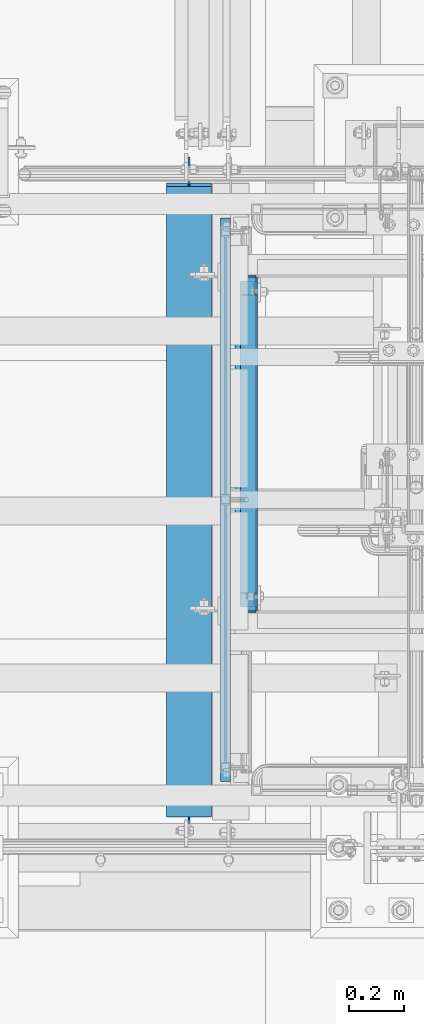
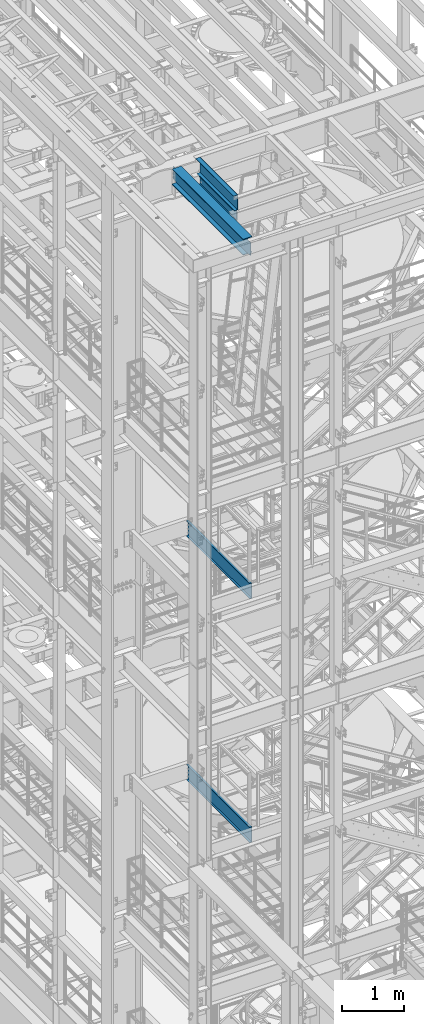
# One storey, part 955 of 1876: 6 beams, 5 elements without a shape of their own.
"""IFC2X3 building model written with IfcOpenShell, lengths in millimetres."""

from ifc_helpers import new_model, si_unit, frame, origin_with_axes, place, context, subcontext, project, spatial, faceted_brep, material, type_object, element, aggregate, save


model = new_model("IFC2X3")

# Units and contexts
model_context = context("Model", 3, precision=1e-05, world=origin_with_axes())
body_context = subcontext(model_context, "Body", "Model", "MODEL_VIEW")
ifc_project = project(units=[si_unit("LENGTHUNIT", "METRE", prefix="MILLI"), si_unit("AREAUNIT", "SQUARE_METRE"), si_unit("VOLUMEUNIT", "CUBIC_METRE"), si_unit("MASSUNIT", "GRAM", prefix="KILO"), si_unit("TIMEUNIT", "SECOND"), si_unit("PLANEANGLEUNIT", "RADIAN"), si_unit("SOLIDANGLEUNIT", "STERADIAN"), si_unit("THERMODYNAMICTEMPERATUREUNIT", "DEGREE_CELSIUS"), si_unit("LUMINOUSINTENSITYUNIT", "LUMEN")], contexts=[model_context])

# Site, building, storey
site_placement = place(None, origin_with_axes())
site = spatial("IfcSite", under=ifc_project, at=site_placement, CompositionType="ELEMENT")
building_placement = place(site_placement, origin_with_axes())
building = spatial("IfcBuilding", under=site, at=building_placement, Name="Undefined", CompositionType="ELEMENT")
storey_placement = place(building_placement, origin_with_axes())
storey = spatial("IfcBuildingStorey", under=building, at=storey_placement, Name="Undefined", CompositionType="ELEMENT", Elevation=0.0)

# Assembly, beam
assembly_1_placement = place(storey_placement, origin_with_axes())
assembly_1 = element("IfcElementAssembly", 1, at=assembly_1_placement, inside=storey, Name="BENT_PLATE", AssemblyPlace="NOTDEFINED", PredefinedType="RIGID_FRAME")
ifc_material_1 = material(Name="STEEL/A36")
beam_type_1 = type_object("IfcBeamType", Name="L3X3X1/4", PredefinedType="NOTDEFINED")
beam_1_placement = place(assembly_1_placement, frame((1158.87500152588, -5022.85, 22831.424987793), z_axis=(-1.0, 0.0, 0.0), x_axis=(0.0, -1.0, 0.0)))
beam_1 = element("IfcBeam", 2, at=beam_1_placement, type_object=beam_type_1, material=ifc_material_1, Name="ANGLE", ObjectType="L3X3X1/4", context=body_context, shape_type="Brep", body=[
    faceted_brep([(0.0, 38.1000000000004, -38.1), (0.0, 38.1000000000004, 38.1), (1231.9, 38.0999999999985, 38.0999999999999), (1231.9, 38.0999999999985, -38.0999999999999), (0.0, 31.75, 38.1000000000004), (1231.9, 31.75, 38.0999999999999), (0.0, 31.75, -31.75), (1231.9, 31.75, -31.75), (0.0, -38.1000000000004, -31.75), (1231.9, -38.0999999999985, -31.75), (0.0, -38.1000000000004, -38.1), (1231.9, -38.0999999999985, -38.0999999999999)], [[[0, 1, 2, 3]], [[1, 4, 5, 2]], [[4, 6, 7, 5]], [[6, 8, 9, 7]], [[8, 10, 11, 9]], [[10, 0, 3, 11]], [[5, 7, 9, 11, 3, 2]], [[10, 8, 6, 4, 1, 0]]]),
])

assembly_2_placement = place(storey_placement, origin_with_axes())
assembly_2 = element("IfcElementAssembly", 3, at=assembly_2_placement, inside=storey, Name="STRINGER", AssemblyPlace="NOTDEFINED", PredefinedType="RIGID_FRAME")
beam_type_2 = type_object("IfcBeamType", Name="MC12X10.6", PredefinedType="NOTDEFINED")
beam_2_placement = place(assembly_2_placement, frame((1085.84999999374, -4813.30000114587, 15442.376851748), z_axis=(0.0, 0.0, 1.0), x_axis=(0.0, -1.0, 0.0)))
beam_2 = element("IfcBeam", 4, at=beam_2_placement, type_object=beam_type_2, material=ifc_material_1, Name="STRINGER", ObjectType="MC12X10.6", context=body_context, shape_type="Brep", body=[
    faceted_brep([(0.0, 19.05, -152.4), (-1.68647966347635e-06, 19.0500000000002, 152.400000000001), (2057.4000000029, 19.05, 152.4), (2057.4000000029, 19.05, -152.4), (-1.68647966347635e-06, -19.0500000000002, 152.400000000001), (2057.4000000029, -19.05, 152.4), (0.0, -19.05, 144.841595), (2057.4000000029, -19.05, 144.841595), (0.0, 14.2874999999999, 144.17817875), (2057.4000000029, 14.2874999999999, 144.17817875), (0.0, 14.2874999999999, -144.17817875), (2057.4000000029, 14.2874999999999, -144.17817875), (0.0, -19.05, -144.841595), (2057.4000000029, -19.05, -144.841595), (0.0, -19.05, -152.4), (2057.4000000029, -19.05, -152.4)], [[[0, 1, 2, 3]], [[1, 4, 5, 2]], [[4, 6, 7, 5]], [[6, 8, 9, 7]], [[8, 10, 11, 9]], [[10, 12, 13, 11]], [[12, 14, 15, 13]], [[14, 0, 3, 15]], [[5, 7, 9, 11, 13, 15, 3, 2]], [[14, 12, 10, 8, 6, 4, 1, 0]]]),
])
aggregate(assembly_2, [beam_2])

assembly_3_placement = place(storey_placement, origin_with_axes())
assembly_3 = element("IfcElementAssembly", 5, at=assembly_3_placement, inside=storey, Name="STRINGER", AssemblyPlace="NOTDEFINED", PredefinedType="RIGID_FRAME")
beam_3_placement = place(assembly_3_placement, frame((1085.85000034225, -4813.30000114536, 10614.0249999981), z_axis=(0.0, 0.0, 1.0), x_axis=(0.0, -1.0, 0.0)))
beam_3 = element("IfcBeam", 6, at=beam_3_placement, type_object=beam_type_2, material=ifc_material_1, Name="STRINGER", ObjectType="MC12X10.6", context=body_context, shape_type="Brep", body=[
    faceted_brep([(0.0, 19.05, -152.4), (-1.68647966347635e-06, 19.0500000000002, 152.400000000001), (2057.4000000029, 19.05, 152.4), (2057.4000000029, 19.05, -152.4), (-1.68647966347635e-06, -19.0500000000002, 152.400000000001), (2057.4000000029, -19.05, 152.4), (0.0, -19.05, 144.841595), (2057.4000000029, -19.05, 144.841595), (0.0, 14.2874999999999, 144.17817875), (2057.4000000029, 14.2874999999999, 144.17817875), (0.0, 14.2874999999999, -144.17817875), (2057.4000000029, 14.2874999999999, -144.17817875), (0.0, -19.05, -144.841595), (2057.4000000029, -19.05, -144.841595), (0.0, -19.05, -152.4), (2057.4000000029, -19.05, -152.4)], [[[0, 1, 2, 3]], [[1, 4, 5, 2]], [[4, 6, 7, 5]], [[6, 8, 9, 7]], [[8, 10, 11, 9]], [[10, 12, 13, 11]], [[12, 14, 15, 13]], [[14, 0, 3, 15]], [[5, 7, 9, 11, 13, 15, 3, 2]], [[14, 12, 10, 8, 6, 4, 1, 0]]]),
])
aggregate(assembly_3, [beam_3])

assembly_4_placement = place(storey_placement, origin_with_axes())
assembly_4 = element("IfcElementAssembly", 7, at=assembly_4_placement, inside=storey, Name="BEAM", AssemblyPlace="NOTDEFINED", PredefinedType="RIGID_FRAME")
ifc_material_2 = material(Name="STEEL/A992")
beam_type_3 = type_object("IfcBeamType", Name="C8X18.75", PredefinedType="NOTDEFINED")
beam_4_placement = place(assembly_4_placement, frame((1171.575, -6248.4, 22453.6), z_axis=(0.0, 0.0, -1.0), x_axis=(0.0, 1.0, 0.0)))
beam_4 = element("IfcBeam", 8, at=beam_4_placement, type_object=beam_type_3, material=ifc_material_2, Name="BEAM", ObjectType="C8X18.75", context=body_context, shape_type="Brep", body=[
    faceted_brep([(1152.525, -31.75, -97.3645499999984), (1152.525, -31.75, -101.599999999999), (1152.525, 31.75, -101.599999999999), (1152.525, 31.75, -95.249999809268), (1152.525, -19.0576219043699, -95.249999809268), (1153.49172992259, 31.75, -90.3899202912216), (1153.49172992259, 10.11452406229, -90.3899202912216), (1154.48641424652, 19.05, -88.9012699999985), (1156.24474382307, 31.75, -86.269743823068), (1156.24474382307, 19.05, -86.269743823068), (1160.36492029122, 31.75, -83.5167299225905), (1160.36492029122, 19.05, -83.5167299225905), (1165.22499980927, 31.75, -82.5500000000029), (1165.22499980927, 19.05, -82.5500000000029), (1203.325, 19.05, -82.5500000000029), (1203.325, 31.75, -82.5500000000029), (15.8749999999991, -31.75, 101.599999999999), (15.8749999999991, -31.75, 97.3645499999984), (1203.325, -31.75, 97.3645499999984), (1203.325, -31.75, 101.599999999999), (15.8749999999991, 31.75, 101.599999999999), (1203.325, 31.75, 101.599999999999), (66.674999999982, -19.0576219043596, -95.2499998092662), (66.674999999982, 31.75, -95.2499998092662), (66.674999999982, 31.75, -101.6), (66.674999999982, -31.75, -101.6), (66.674999999982, -31.75, -97.3645500000002), (65.708270077394, 10.1145240623009, -90.3899202912198), (65.708270077394, 31.75, -90.3899202912198), (64.7135857534681, 19.0500000000002, -88.9012700000003), (62.955256176916, 19.0500000000002, -86.2697438230662), (62.955256176916, 31.75, -86.2697438230662), (58.8350797087624, 19.0500000000002, -83.5167299225886), (58.8350797087624, 31.75, -83.5167299225886), (53.9750001907169, 19.0500000000002, -82.5500000000011), (53.9750001907169, 31.75, -82.5500000000011), (15.8749999999991, 19.0500000000002, -82.5499999999993), (15.8749999999991, 31.75, -82.5499999999993), (15.8749999999991, 19.0500000000002, 88.9012699999985), (1203.325, 19.05, 88.9012699999985)], [[[0, 1, 2, 3, 4]], [[4, 3, 5, 6]], [[7, 6, 5, 8, 9]], [[9, 8, 10, 11]], [[11, 10, 12, 13]], [[14, 13, 12, 15]], [[16, 17, 18, 19]], [[20, 16, 19, 21]], [[22, 23, 24, 25, 26]], [[27, 28, 23, 22]], [[29, 30, 31, 28, 27]], [[32, 33, 31, 30]], [[34, 35, 33, 32]], [[36, 37, 35, 34]], [[38, 17, 16, 20, 37, 36]], [[17, 38, 39, 18]], [[21, 19, 18, 39, 14, 15]], [[10, 8, 5, 3, 2, 24, 23, 28, 31, 33, 35, 37, 20, 21, 15, 12]], [[25, 24, 2, 1]], [[26, 25, 1, 0]], [[29, 27, 22, 26, 0, 4, 6, 7]], [[39, 38, 36, 34, 32, 30, 29, 7, 9, 11, 13, 14]]]),
])
aggregate(assembly_4, [beam_4])

# Beam
beam_type_4 = type_object("IfcBeamType", PredefinedType="NOTDEFINED")
beam_5_placement = place(assembly_1_placement, frame((1139.82499999998, -5638.8, 22567.9), z_axis=(0.0, 1.0, 0.0), x_axis=(1.0, 0.0, 0.0)))
beam_5 = element("IfcBeam", 9, at=beam_5_placement, type_object=beam_type_4, material=ifc_material_1, Name="BENT_PLATE", context=body_context, shape_type="Brep", body=[
    faceted_brep([(0.0, -3.17499999999927, -609.6), (0.0, -3.17499999999927, 609.6), (0.0, 3.17499999999927, 609.6), (0.0, 3.17499999999927, -609.6), (63.5000000000182, 3.17499999999927, 609.6), (63.5000000000182, 3.17499999999927, -609.6), (57.1500000000178, -3.17499999999927, -609.6), (57.1500000000178, -3.17499999999927, 609.6), (63.5000000000182, -301.624987792951, 609.6), (63.5000000000182, -301.624987792951, -609.6), (57.1500000000178, -301.624987792951, 609.6), (57.1500000000178, -301.624987792951, -609.6)], [[[0, 1, 2, 3]], [[3, 2, 4, 5]], [[1, 0, 6, 7]], [[5, 4, 8, 9]], [[4, 2, 1, 7, 10, 8]], [[7, 6, 11, 10]], [[6, 0, 3, 5, 9, 11]], [[10, 11, 9, 8]]]),
])

aggregate(assembly_1, [beam_1, beam_5])

# Assembly, beam
assembly_5_placement = place(storey_placement, origin_with_axes())
assembly_5 = element("IfcElementAssembly", 10, at=assembly_5_placement, inside=storey, Name="BEAM", AssemblyPlace="NOTDEFINED", PredefinedType="RIGID_FRAME")
beam_type_5 = type_object("IfcBeamType", Name="W12X35", PredefinedType="NOTDEFINED")
beam_6_placement = place(assembly_5_placement, frame((952.5, -7112.0, 22396.45), z_axis=(0.0, 0.0, 1.0), x_axis=(0.0, 1.0, 0.0)))
beam_6 = element("IfcBeam", 11, at=beam_6_placement, type_object=beam_type_5, material=ifc_material_2, Name="BEAM", ObjectType="W12X35", context=body_context, shape_type="Brep", body=[
    faceted_brep([(2424.90625, -82.5500000000002, -146.049999999999), (2424.90625, -82.5500000000002, -158.75), (2424.90625, 82.5500000000002, -158.75), (2424.90625, 82.5500000000002, -146.049999999999), (2424.90625, 3.96875, -146.049999999999), (2424.90625, -3.96875, -146.049999999999), (2425.87297992259, 3.96875, -141.189920291214), (2425.87297992259, -3.96875, -141.189920291214), (2428.62599382307, 3.96875, -137.06974382306), (2428.62599382307, -3.96875, -137.06974382306), (2432.74617029122, 3.96875, -134.316729922582), (2432.74617029122, -3.96875, -134.316729922582), (2437.60624980927, 3.96875, -133.349999999995), (2437.60624980927, -3.96875, -133.349999999995), (2520.15625, -3.96875, -133.349999999995), (2520.15625, 3.96875, -133.349999999995), (2412.20625, 82.5500000000002, 146.049999999999), (2412.20625, 3.96875, 146.049999999999), (112.712500000001, 3.96875, 146.049999999999), (112.712500000001, 82.5500000000002, 146.05), (112.712500000001, -82.5500000000002, -146.049999999999), (112.712500000001, -3.96875, -146.049999999999), (112.712500000001, 3.96875, -146.049999999999), (112.712500000001, 82.5500000000002, -146.049999999999), (112.712500000001, 82.5500000000002, -158.75), (112.712500000001, -82.5500000000002, -158.75), (111.745770077413, -3.96875, -141.189920291221), (111.745770077413, 3.96875, -141.189920291221), (108.992756176935, -3.96875, -137.069743823067), (108.992756176935, 3.96875, -137.069743823067), (104.872579708781, -3.96875, -134.31672992259), (104.872579708781, 3.96875, -134.31672992259), (100.012500190735, -3.96875, -133.350000000002), (100.012500190735, 3.96875, -133.350000000002), (17.4624999999996, -3.96875, -133.350000000002), (17.4624999999996, 3.96875, -133.350000000002), (17.4624999999996, -3.96875, 120.649999999998), (17.4624999999996, 3.96875, 120.649999999998), (100.012500190735, -3.96875, 120.649999999998), (100.012500190735, 3.96875, 120.649999999998), (104.872579708781, -3.96875, 121.616729922585), (104.872579708781, 3.96875, 121.616729922585), (108.992756176935, -3.96875, 124.369743823063), (108.992756176935, 3.96875, 124.369743823063), (111.745770077413, -3.96875, 128.489920291217), (111.745770077413, 3.96875, 128.489920291217), (112.712500000001, -3.96875, 133.349999809263), (112.712500000001, 3.96875, 133.349999809263), (112.712500000001, -82.5500000000002, 158.75), (112.712500000001, 82.5500000000002, 158.75), (112.712500000001, -3.96875, 146.049999999999), (112.712500000001, -82.5500000000002, 146.05), (2412.20625, -3.96875, 146.049999999999), (2412.20625, -82.5500000000002, 146.049999999999), (2412.20625, -82.5500000000002, 158.75), (2412.20625, 82.5500000000002, 158.75), (2412.20625, -3.96875, 133.34999980927), (2412.20625, 3.96875, 133.34999980927), (2413.17297992259, -3.96875, 128.489920291224), (2413.17297992259, 3.96875, 128.489920291224), (2415.92599382307, -3.96875, 124.36974382307), (2415.92599382307, 3.96875, 124.36974382307), (2420.04617029122, -3.96875, 121.616729922593), (2420.04617029122, 3.96875, 121.616729922593), (2424.90624980927, -3.96875, 120.650000000005), (2424.90624980927, 3.96875, 120.650000000005), (2520.15625, -3.96875, 120.650000000005), (2520.15625, 3.96875, 120.650000000005)], [[[0, 1, 2, 3, 4, 5]], [[5, 4, 6, 7]], [[7, 6, 8, 9]], [[9, 8, 10, 11]], [[11, 10, 12, 13]], [[14, 13, 12, 15]], [[16, 17, 18, 19]], [[20, 21, 22, 23, 24, 25]], [[26, 27, 22, 21]], [[28, 29, 27, 26]], [[30, 31, 29, 28]], [[32, 33, 31, 30]], [[34, 35, 33, 32]], [[36, 37, 35, 34]], [[38, 39, 37, 36]], [[40, 41, 39, 38]], [[42, 43, 41, 40]], [[44, 45, 43, 42]], [[46, 47, 45, 44]], [[48, 49, 19, 18, 47, 46, 50, 51]], [[52, 53, 51, 50]], [[53, 54, 48, 51]], [[54, 55, 49, 48]], [[55, 16, 19, 49]], [[54, 53, 52, 56, 57, 17, 16, 55]], [[58, 59, 57, 56]], [[60, 61, 59, 58]], [[62, 63, 61, 60]], [[64, 65, 63, 62]], [[66, 67, 65, 64]], [[67, 66, 14, 15]], [[29, 31, 33, 35, 37, 39, 41, 43, 45, 47, 18, 17, 57, 59, 61, 63, 65, 67, 15, 12, 10, 8, 6, 4, 22, 27]], [[4, 3, 23, 22]], [[3, 2, 24, 23]], [[2, 1, 25, 24]], [[1, 0, 20, 25]], [[0, 5, 21, 20]], [[5, 7, 9, 11, 13, 14, 66, 64, 62, 60, 58, 56, 52, 50, 46, 44, 42, 40, 38, 36, 34, 32, 30, 28, 26, 21]]]),
])
aggregate(assembly_5, [beam_6])

save(model, "model.ifc")
